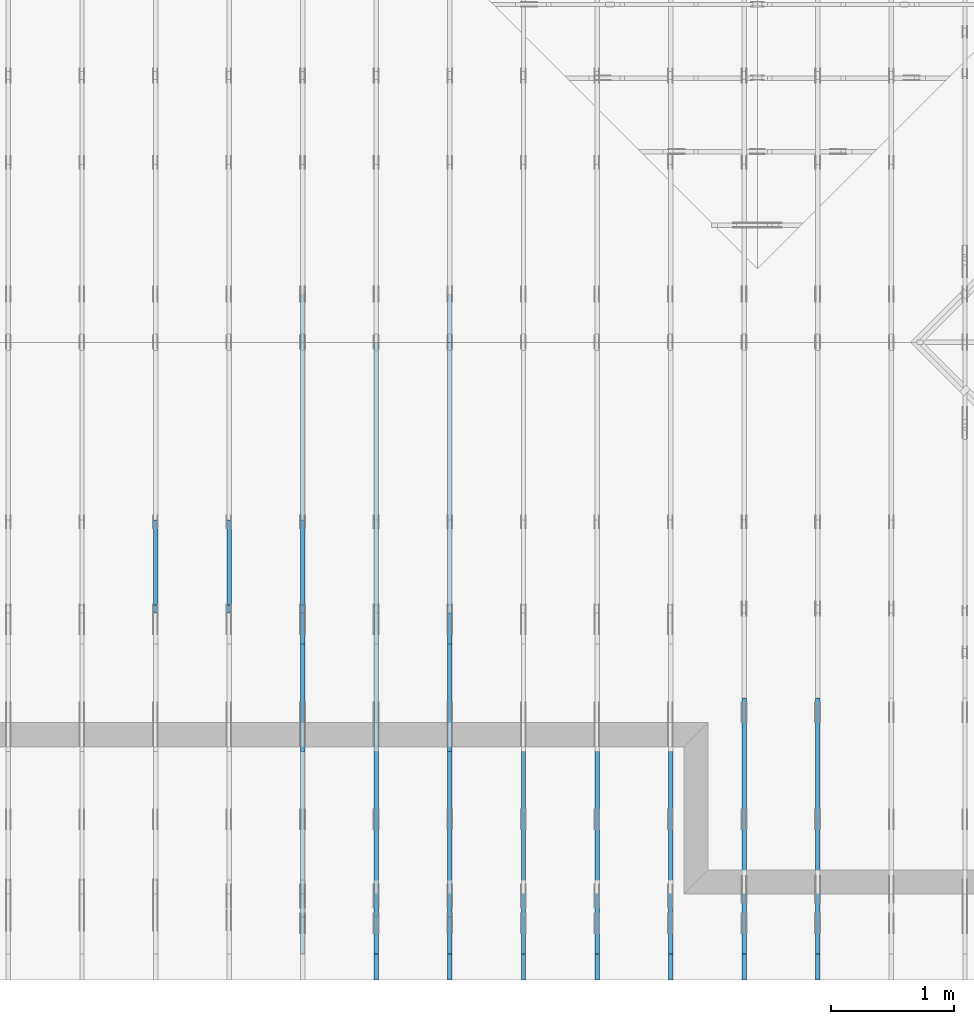
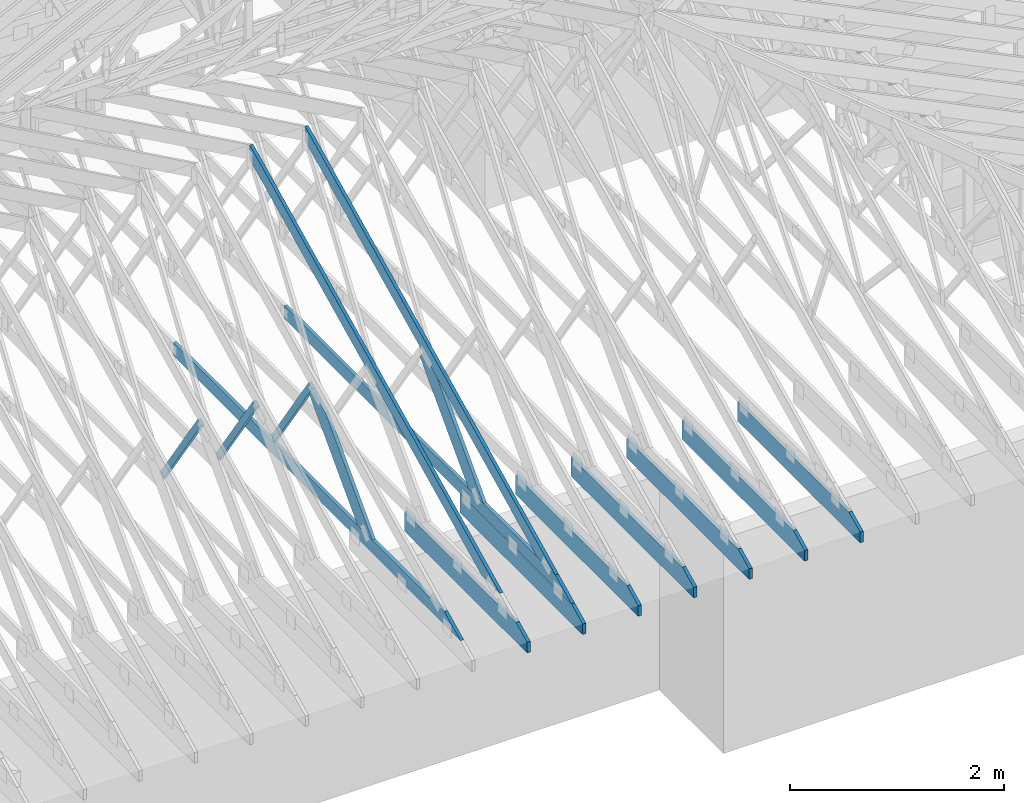
# One storey, part 13 of 159: 16 members, 10 elements without a shape of their own.
"""IFC2X3 building model written with IfcOpenShell, lengths in millimetres."""

from ifc_helpers import new_model, si_unit, frame, origin, origin_with_axes, origin_2d, place, context, project, spatial, faceted_brep, element, aggregate, save


model = new_model("IFC2X3")

# Units and contexts
model_context = context("Model", 3, precision=1e-05, world=origin())
plan_context = context("Plan", 2, precision=1e-05, world=origin_2d())
ifc_project = project(units=[si_unit("LENGTHUNIT", "METRE", prefix="MILLI"), si_unit("AREAUNIT", "SQUARE_METRE"), si_unit("VOLUMEUNIT", "CUBIC_METRE"), si_unit("SOLIDANGLEUNIT", "STERADIAN"), si_unit("PLANEANGLEUNIT", "RADIAN"), si_unit("MASSUNIT", "GRAM"), si_unit("TIMEUNIT", "SECOND"), si_unit("THERMODYNAMICTEMPERATUREUNIT", "DEGREE_CELSIUS"), si_unit("LUMINOUSINTENSITYUNIT", "LUMEN")], contexts=[model_context, plan_context])

# Site, building, storey
site_placement = place(None, origin_with_axes())
site = spatial("IfcSite", under=ifc_project, at=site_placement, CompositionType="ELEMENT")
building_placement = place(site_placement, origin_with_axes())
building = spatial("IfcBuilding", under=site, at=building_placement, Name="Plan 1", CompositionType="ELEMENT")
storey_placement = place(building_placement, origin_with_axes())
storey = spatial("IfcBuildingStorey", under=building, at=storey_placement, Name="Etasje 1", CompositionType="ELEMENT", Elevation=0.0)

# Assembly, member
assembly_1_placement = place(storey_placement, frame((15075.02226140475, -699.9989301294845, 1.1021457184401395e-15), z_axis=(-1.0, 1.836909530733566e-16, 6.123031769111886e-17), x_axis=(-1.836909530733566e-16, -1.0, 0.0)))
assembly_1 = element("IfcElementAssembly", 1, at=assembly_1_placement, inside=storey, Name="T7 (103)", AssemblyPlace="FACTORY", PredefinedType="TRUSS")
member_1_placement = place(assembly_1_placement, frame((-2299.9990234375, 0.0, -36.0), z_axis=(0.0, 0.0, 1.0), x_axis=(1.0, 0.0, 0.0)))
member_1 = element("IfcMember", 2, at=member_1_placement, Name="T7-U14", context=model_context, shape_type="Brep", body=[
    faceted_brep([(2088.8177337646484, 223.0, 36.0), (0.0, 223.0, 36.0), (0.0, 0.0, 36.0), (2300.0000933080446, 0.0, 36.0), (2300.0000933080446, 119.99948120117188, 36.0), (0.0, 223.0, 0.0), (2088.8177337646484, 223.0, 2.5579794687450473e-13), (2300.0000933080446, 119.99948120117188, 2.816594728057092e-13), (2300.0000933080446, 0.0, 2.816594728057092e-13), (0.0, 0.0, 0.0), (2088.8177277548316, 223.00000000000023, 2.524354896707238e-29), (2088.8177277548316, 223.00000000000023, 36.0), (2300.0000933080146, 119.99947818928456, 36.0), (2300.0000933080146, 119.99947818928456, 2.524354896707238e-29), (9.330801458418136e-05, 223.0, 0.0), (9.330801458418136e-05, 223.0, 36.0), (2088.817727754831, 222.99999999999986, 36.0), (2088.817727754831, 222.99999999999986, -7.888609052210118e-30), (9.330801458418136e-05, 0.0, 0.0), (9.330801458638566e-05, -2.6993892992798474e-31, 36.0), (9.330801461369438e-05, 223.0, 36.0), (9.330801461149009e-05, 223.0, -1.6721217180559947e-30), (2300.0000933080146, -4.2248920920855827e-13, 2.5869148500909603e-29), (2300.0000933080146, -4.20284917771678e-13, 36.0), (9.330801458418136e-05, 2.204274297042151e-15, 36.0), (9.330801458418136e-05, -1.713983812835093e-20, 1.0494777337732796e-36), (2300.0000933080146, 119.99947818928416, 0.0), (2300.0000933080146, 119.99947818928416, 36.0), (2300.0000933080146, 0.0, 36.0), (2300.0000933080146, 0.0, 0.0)], [[[0, 1, 2, 3, 4]], [[5, 6, 7, 8, 9]], [[10, 11, 12, 13]], [[14, 15, 16, 17]], [[18, 19, 20, 21]], [[22, 23, 24, 25]], [[26, 27, 28, 29]]]),
])
aggregate(assembly_1, [member_1])

assembly_2_placement = place(storey_placement, frame((14475.022261404752, -699.9989301294836, 1.1021457184401395e-15), z_axis=(-1.0, 1.836909530733566e-16, 6.123031769111886e-17), x_axis=(-1.836909530733566e-16, -1.0, 0.0)))
assembly_2 = element("IfcElementAssembly", 3, at=assembly_2_placement, inside=storey, Name="T10 (102)", AssemblyPlace="FACTORY", PredefinedType="TRUSS")
member_2_placement = place(assembly_2_placement, frame((-2299.9990234375, 0.0, -36.0), z_axis=(0.0, 0.0, 1.0), x_axis=(1.0, 0.0, 0.0)))
member_2 = element("IfcMember", 4, at=member_2_placement, Name="T10-U14", context=model_context, shape_type="Brep", body=[
    faceted_brep([(2088.8177337646484, 223.0, 36.0), (0.0, 223.0, 36.0), (0.0, 0.0, 36.0), (2300.0000933080446, 0.0, 36.0), (2300.0000933080446, 119.99948120117188, 36.0), (0.0, 223.0, 0.0), (2088.8177337646484, 223.0, 2.5579794687450473e-13), (2300.0000933080446, 119.99948120117188, 2.816594728057092e-13), (2300.0000933080446, 0.0, 2.816594728057092e-13), (0.0, 0.0, 0.0), (2088.8177277548316, 223.00000000000023, 2.524354896707238e-29), (2088.8177277548316, 223.00000000000023, 36.0), (2300.0000933080146, 119.99947818928456, 36.0), (2300.0000933080146, 119.99947818928456, 2.524354896707238e-29), (9.330801458418136e-05, 223.0, 0.0), (9.330801458418136e-05, 223.0, 36.0), (2088.817727754831, 222.99999999999986, 36.0), (2088.817727754831, 222.99999999999986, -7.888609052210118e-30), (9.330801458418136e-05, 0.0, 0.0), (9.330801458638566e-05, -2.6993892992798474e-31, 36.0), (9.330801461369438e-05, 223.0, 36.0), (9.330801461149009e-05, 223.0, -1.6721217180559947e-30), (2300.0000933080146, -4.2248920920855827e-13, 2.5869148500909603e-29), (2300.0000933080146, -4.20284917771678e-13, 36.0), (9.330801458418136e-05, 2.204274297042151e-15, 36.0), (9.330801458418136e-05, -1.713983812835093e-20, 1.0494777337732796e-36), (2300.0000933080146, 119.99947818928416, 0.0), (2300.0000933080146, 119.99947818928416, 36.0), (2300.0000933080146, 0.0, 36.0), (2300.0000933080146, 0.0, 0.0)], [[[0, 1, 2, 3, 4]], [[5, 6, 7, 8, 9]], [[10, 11, 12, 13]], [[14, 15, 16, 17]], [[18, 19, 20, 21]], [[22, 23, 24, 25]], [[26, 27, 28, 29]]]),
])
aggregate(assembly_2, [member_2])

assembly_3_placement = place(storey_placement, frame((13875.022261404752, -699.9989301294836, 1.1021457184401395e-15), z_axis=(-1.0, 1.836909530733566e-16, 6.123031769111886e-17), x_axis=(-1.836909530733566e-16, -1.0, 0.0)))
assembly_3 = element("IfcElementAssembly", 5, at=assembly_3_placement, inside=storey, Name="T6 (101)", AssemblyPlace="FACTORY", PredefinedType="TRUSS")
member_3_placement = place(assembly_3_placement, frame((-2299.9990234375, 0.0, -36.0), z_axis=(0.0, 0.0, 1.0), x_axis=(1.0, 0.0, 0.0)))
member_3 = element("IfcMember", 6, at=member_3_placement, Name="T6-U14", context=model_context, shape_type="Brep", body=[
    faceted_brep([(2088.8177337646484, 223.0, 36.0), (0.0, 223.0, 36.0), (0.0, 0.0, 36.0), (2300.0000933080446, 0.0, 36.0), (2300.0000933080446, 119.99948120117188, 36.0), (0.0, 223.0, 0.0), (2088.8177337646484, 223.0, 2.5579794687450473e-13), (2300.0000933080446, 119.99948120117188, 2.816594728057092e-13), (2300.0000933080446, 0.0, 2.816594728057092e-13), (0.0, 0.0, 0.0), (2088.8177277548316, 223.00000000000023, 2.524354896707238e-29), (2088.8177277548316, 223.00000000000023, 36.0), (2300.0000933080146, 119.99947818928456, 36.0), (2300.0000933080146, 119.99947818928456, 2.524354896707238e-29), (9.330801458418136e-05, 223.0, 0.0), (9.330801458418136e-05, 223.0, 36.0), (2088.817727754831, 222.99999999999986, 36.0), (2088.817727754831, 222.99999999999986, -7.888609052210118e-30), (9.330801458418136e-05, 0.0, 0.0), (9.330801458638566e-05, -2.6993892992798474e-31, 36.0), (9.330801461369438e-05, 223.0, 36.0), (9.330801461149009e-05, 223.0, -1.6721217180559947e-30), (2300.0000933080146, -4.2248920920855827e-13, 2.5869148500909603e-29), (2300.0000933080146, -4.20284917771678e-13, 36.0), (9.330801458418136e-05, 2.204274297042151e-15, 36.0), (9.330801458418136e-05, -1.713983812835093e-20, 1.0494777337732796e-36), (2300.0000933080146, 119.99947818928416, 0.0), (2300.0000933080146, 119.99947818928416, 36.0), (2300.0000933080146, 0.0, 36.0), (2300.0000933080146, 0.0, 0.0)], [[[0, 1, 2, 3, 4]], [[5, 6, 7, 8, 9]], [[10, 11, 12, 13]], [[14, 15, 16, 17]], [[18, 19, 20, 21]], [[22, 23, 24, 25]], [[26, 27, 28, 29]]]),
])
aggregate(assembly_3, [member_3])

assembly_4_placement = place(storey_placement, frame((13275.022261404752, -699.9989301294836, 1.1021457184401395e-15), z_axis=(-1.0, 1.836909530733566e-16, 6.123031769111886e-17), x_axis=(-1.836909530733566e-16, -1.0, 0.0)))
assembly_4 = element("IfcElementAssembly", 7, at=assembly_4_placement, inside=storey, Name="T6 (100)", AssemblyPlace="FACTORY", PredefinedType="TRUSS")
member_4_placement = place(assembly_4_placement, frame((-2299.9990234375, 0.0, -36.0), z_axis=(0.0, 0.0, 1.0), x_axis=(1.0, 0.0, 0.0)))
member_4 = element("IfcMember", 8, at=member_4_placement, Name="T6-U14", context=model_context, shape_type="Brep", body=[
    faceted_brep([(2088.8177337646484, 223.0, 36.0), (0.0, 223.0, 36.0), (0.0, 0.0, 36.0), (2300.0000933080446, 0.0, 36.0), (2300.0000933080446, 119.99948120117188, 36.0), (0.0, 223.0, 0.0), (2088.8177337646484, 223.0, 2.5579794687450473e-13), (2300.0000933080446, 119.99948120117188, 2.816594728057092e-13), (2300.0000933080446, 0.0, 2.816594728057092e-13), (0.0, 0.0, 0.0), (2088.8177277548316, 223.00000000000023, 2.524354896707238e-29), (2088.8177277548316, 223.00000000000023, 36.0), (2300.0000933080146, 119.99947818928456, 36.0), (2300.0000933080146, 119.99947818928456, 2.524354896707238e-29), (9.330801458418136e-05, 223.0, 0.0), (9.330801458418136e-05, 223.0, 36.0), (2088.817727754831, 222.99999999999986, 36.0), (2088.817727754831, 222.99999999999986, -7.888609052210118e-30), (9.330801458418136e-05, 0.0, 0.0), (9.330801458638566e-05, -2.6993892992798474e-31, 36.0), (9.330801461369438e-05, 223.0, 36.0), (9.330801461149009e-05, 223.0, -1.6721217180559947e-30), (2300.0000933080146, -4.2248920920855827e-13, 2.5869148500909603e-29), (2300.0000933080146, -4.20284917771678e-13, 36.0), (9.330801458418136e-05, 2.204274297042151e-15, 36.0), (9.330801458418136e-05, -1.713983812835093e-20, 1.0494777337732796e-36), (2300.0000933080146, 119.99947818928416, 0.0), (2300.0000933080146, 119.99947818928416, 36.0), (2300.0000933080146, 0.0, 36.0), (2300.0000933080146, 0.0, 0.0)], [[[0, 1, 2, 3, 4]], [[5, 6, 7, 8, 9]], [[10, 11, 12, 13]], [[14, 15, 16, 17]], [[18, 19, 20, 21]], [[22, 23, 24, 25]], [[26, 27, 28, 29]]]),
])
aggregate(assembly_4, [member_4])

assembly_5_placement = place(storey_placement, frame((12675.022261404752, -699.9989301294854, 4.558494966049043e-13), z_axis=(-1.0, 1.836909530733566e-16, 6.123031769111886e-17), x_axis=(-1.836909530733566e-16, -1.0, 0.0)))
assembly_5 = element("IfcElementAssembly", 9, at=assembly_5_placement, inside=storey, Name="T6 (99)", AssemblyPlace="FACTORY", PredefinedType="TRUSS")
member_5_placement = place(assembly_5_placement, frame((-2299.9990234375, 0.0, -36.0), z_axis=(0.0, 0.0, 1.0), x_axis=(1.0, 0.0, 0.0)))
member_5 = element("IfcMember", 10, at=member_5_placement, Name="T6-U14", context=model_context, shape_type="Brep", body=[
    faceted_brep([(2088.8177337646484, 223.0, 36.0), (0.0, 223.0, 36.0), (0.0, 0.0, 36.0), (2300.0000933080446, 0.0, 36.0), (2300.0000933080446, 119.99948120117188, 36.0), (0.0, 223.0, 0.0), (2088.8177337646484, 223.0, 2.5579794687450473e-13), (2300.0000933080446, 119.99948120117188, 2.816594728057092e-13), (2300.0000933080446, 0.0, 2.816594728057092e-13), (0.0, 0.0, 0.0), (2088.8177277548316, 223.00000000000023, 2.524354896707238e-29), (2088.8177277548316, 223.00000000000023, 36.0), (2300.0000933080146, 119.99947818928456, 36.0), (2300.0000933080146, 119.99947818928456, 2.524354896707238e-29), (9.330801458418136e-05, 223.0, 0.0), (9.330801458418136e-05, 223.0, 36.0), (2088.817727754831, 222.99999999999986, 36.0), (2088.817727754831, 222.99999999999986, -7.888609052210118e-30), (9.330801458418136e-05, 0.0, 0.0), (9.330801458638566e-05, -2.6993892992798474e-31, 36.0), (9.330801461369438e-05, 223.0, 36.0), (9.330801461149009e-05, 223.0, -1.6721217180559947e-30), (2300.0000933080146, -4.2248920920855827e-13, 2.5869148500909603e-29), (2300.0000933080146, -4.20284917771678e-13, 36.0), (9.330801458418136e-05, 2.204274297042151e-15, 36.0), (9.330801458418136e-05, -1.713983812835093e-20, 1.0494777337732796e-36), (2300.0000933080146, 119.99947818928416, 0.0), (2300.0000933080146, 119.99947818928416, 36.0), (2300.0000933080146, 0.0, 36.0), (2300.0000933080146, 0.0, 0.0)], [[[0, 1, 2, 3, 4]], [[5, 6, 7, 8, 9]], [[10, 11, 12, 13]], [[14, 15, 16, 17]], [[18, 19, 20, 21]], [[22, 23, 24, 25]], [[26, 27, 28, 29]]]),
])
aggregate(assembly_5, [member_5])

# Assembly, members
assembly_6_placement = place(storey_placement, frame((12075.022261404752, -699.9989301294854, 4.558494966049043e-13), z_axis=(-1.0, 1.836909530733566e-16, 6.123031769111886e-17), x_axis=(-1.836909530733566e-16, -1.0, 0.0)))
assembly_6 = element("IfcElementAssembly", 11, at=assembly_6_placement, inside=storey, Name="T5 (98)", AssemblyPlace="FACTORY", PredefinedType="TRUSS")
member_6_placement = place(assembly_6_placement, frame((-5264.878447895178, 2523.1876964355156, -36.0), z_axis=(0.0, 0.0, 1.0), x_axis=(0.8987940462991668, -0.4383711467890778, 0.0)))
member_6 = element("IfcMember", 12, at=member_6_placement, Name="T5-O3", context=model_context, shape_type="Brep", body=[
    faceted_brep([(5212.95535395332, 148.00000154094027, 36.0), (0.0, 148.00000154094027, 36.0), (72.18440200989608, 5.7974317996922764e-05, 36.0), (4909.510382240189, 5.7974317996922764e-05, 36.0), (0.0, 148.00000154094027, 0.0), (5212.95535395332, 148.00000154094027, 6.383818248643616e-13), (4909.510382240189, 5.7974317996922764e-05, 6.012217608248263e-13), (72.18440200989608, 5.7974317996922764e-05, 8.839747734818752e-15), (72.18447769922204, 9.2140264804641e-06, -7.888609052210118e-31), (72.18447769922206, 9.2140264804641e-06, 36.0), (5.4591825588090614e-05, 148.00000921330525, 36.0), (5.4591825588090614e-05, 148.00000921330525, -7.888609052210118e-31), (4909.510401129447, 9.21290418597988e-06, 1.6550270895783706e-28), (4909.510401129447, 9.212904188184172e-06, 36.0), (72.18447769922204, 9.21402643937418e-06, 36.0), (72.18447769922204, 9.214026437169889e-06, 2.433384460947949e-30), (5212.955369681814, 148.00000921223887, 1.0605704288840677e-29), (5212.955369681814, 148.00000921223887, 36.0), (4909.510401129447, 9.212906661559828e-06, 36.0), (4909.510401129447, 9.212906661559828e-06, -1.359749288005947e-29), (5.459182557387976e-05, 148.00000921330525, 0.0), (5.459182557387976e-05, 148.00000921330525, 36.0), (5212.955369681813, 148.00000921223887, 36.0), (5212.955369681813, 148.00000921223887, 7.888609052210118e-30)], [[[0, 1, 2, 3]], [[4, 5, 6, 7]], [[8, 9, 10, 11]], [[12, 13, 14, 15]], [[16, 17, 18, 19]], [[20, 21, 22, 23]]]),
])
member_7_placement = place(assembly_6_placement, frame((-211.18128967285153, 370.99999999999994, -36.0), z_axis=(0.0, 0.0, 1.0), x_axis=(-1.0, 1.2246063538223773e-16, 0.0)))
member_7 = element("IfcMember", 13, at=member_7_placement, Name="T5-U32", context=model_context, shape_type="Brep", body=[
    faceted_brep([(5379.999862670898, 148.00000000000063, 36.0), (0.0, 148.00000000000063, 36.0), (303.4449920654297, 0.0, 36.0), (5379.999862670898, 0.0, 36.0), (0.0, 148.00000000000063, 0.0), (5379.999862670898, 148.00000000000063, 6.588382015390299e-13), (5379.999862670898, 0.0, 6.588382015390299e-13), (303.4449920654297, 0.0, 3.7160066531890605e-14), (303.44497456401575, -1.8474111129762605e-13, 1.4199496293978212e-29), (303.44497456401575, -1.8474111129762605e-13, 36.0), (6.010755903673726e-06, 148.0, 36.0), (6.010755903673726e-06, 148.0, -1.5777218104420236e-30), (5380.000006010756, -1.0494167752128893e-12, 1.2690585325561372e-28), (5380.000006010756, -1.047212483776009e-12, 36.0), (303.44497456401587, -1.146952517202135e-13, 36.0), (303.44497456401587, -1.1689954315709379e-13, 7.157796165455513e-30), (5380.000006010756, 148.000000000001, 0.0), (5380.000006010756, 148.000000000001, 36.0), (5380.000006010756, 1.0231815394945443e-12, 36.0), (5380.000006010756, 1.0231815394945443e-12, 0.0), (6.010755896568298e-06, 147.99999999999997, 0.0), (6.010755896568298e-06, 147.99999999999997, 36.0), (5380.000006010756, 148.00000000000082, 36.0), (5380.000006010756, 148.00000000000082, -9.466330862652142e-30)], [[[0, 1, 2, 3]], [[4, 5, 6, 7]], [[8, 9, 10, 11]], [[12, 13, 14, 15]], [[16, 17, 18, 19]], [[20, 21, 22, 23]]]),
])
member_8_placement = place(assembly_6_placement, frame((-2299.9990234375, 0.0, -36.0), z_axis=(0.0, 0.0, 1.0), x_axis=(1.0, 0.0, 0.0)))
member_8 = element("IfcMember", 14, at=member_8_placement, Name="T5-U14", context=model_context, shape_type="Brep", body=[
    faceted_brep([(2088.8177337646484, 223.0, 36.0), (0.0, 223.0, 36.0), (0.0, 0.0, 36.0), (2300.0000933080446, 0.0, 36.0), (2300.0000933080446, 119.99948120117188, 36.0), (0.0, 223.0, 0.0), (2088.8177337646484, 223.0, 2.5579794687450473e-13), (2300.0000933080446, 119.99948120117188, 2.816594728057092e-13), (2300.0000933080446, 0.0, 2.816594728057092e-13), (0.0, 0.0, 0.0), (2088.8177277548316, 223.00000000000023, 2.524354896707238e-29), (2088.8177277548316, 223.00000000000023, 36.0), (2300.0000933080146, 119.99947818928456, 36.0), (2300.0000933080146, 119.99947818928456, 2.524354896707238e-29), (9.330801458418136e-05, 223.0, 0.0), (9.330801458418136e-05, 223.0, 36.0), (2088.817727754831, 222.99999999999986, 36.0), (2088.817727754831, 222.99999999999986, -7.888609052210118e-30), (9.330801458418136e-05, 0.0, 0.0), (9.330801458638566e-05, -2.6993892992798474e-31, 36.0), (9.330801461369438e-05, 223.0, 36.0), (9.330801461149009e-05, 223.0, -1.6721217180559947e-30), (2300.0000933080146, -4.2248920920855827e-13, 2.5869148500909603e-29), (2300.0000933080146, -4.20284917771678e-13, 36.0), (9.330801458418136e-05, 2.204274297042151e-15, 36.0), (9.330801458418136e-05, -1.713983812835093e-20, 1.0494777337732796e-36), (2300.0000933080146, 119.99947818928416, 0.0), (2300.0000933080146, 119.99947818928416, 36.0), (2300.0000933080146, 0.0, 36.0), (2300.0000933080146, 0.0, 0.0)], [[[0, 1, 2, 3, 4]], [[5, 6, 7, 8, 9]], [[10, 11, 12, 13]], [[14, 15, 16, 17]], [[18, 19, 20, 21]], [[22, 23, 24, 25]], [[26, 27, 28, 29]]]),
])
member_9_placement = place(assembly_6_placement, frame((-3064.6757649958863, 1346.8492734428223, -36.0), z_axis=(0.0, 0.0, 1.0), x_axis=(0.6894016878176602, -0.7243792603561765, 0.0)))
member_9 = element("IfcMember", 15, at=member_9_placement, Name="T5-D3", context=model_context, shape_type="Brep", body=[
    faceted_brep([(1535.5918255141082, 198.00009159272804, 36.0), (265.95807658513104, 198.00009159272804, 36.0), (0.0, 99.00008285369722, 36.0), (21.1644449327855, 0.0, 36.0), (1347.1524748391525, 0.0, 36.0), (265.95807658513104, 198.00009159272804, 3.256939504365299e-14), (1535.5918255141082, 198.00009159272804, 1.8804955064022803e-13), (1347.1524748391525, 0.0, 1.6497314802555664e-13), (21.1644449327855, 0.0, 2.5918113739812938e-15), (0.0, 99.00008285369722, 0.0), (4.264463813541397e-05, 99.00009494304574, 8.9528506660674e-31), (4.264463813541397e-05, 99.00009494304574, 36.0), (265.9581340926615, 198.000094942845, 36.0), (265.9581340926615, 198.000094942845, 5.714073875343044e-30), (21.164497648067943, 9.494284540778608e-05, -1.97215226305253e-31), (21.164497648067943, 9.494284540867426e-05, 36.0), (4.264463818515196e-05, 99.00009494304575, 36.0), (4.264463818159925e-05, 99.00009494304575, -2.5637979419682884e-30), (1347.1525101598781, 9.494284280359457e-05, 2.0233849336071296e-29), (1347.1525101598781, 9.494284280579886e-05, 36.0), (21.164497648067936, 9.494284540479874e-05, 36.0), (21.164497648067936, 9.494284540259445e-05, 3.1788526975049665e-31), (1535.5918287024588, 198.00009494284234, 5.048709793414476e-29), (1535.5918287024588, 198.00009494284234, 36.0), (1347.1525101598784, 9.494284279298881e-05, 36.0), (1347.1525101598784, 9.494284279298881e-05, 3.7865323450608567e-29), (265.95813409266157, 198.00009494284495, 0.0), (265.95813409266157, 198.00009494284495, 36.0), (1535.5918287024583, 198.00009494284262, 36.0), (1535.5918287024583, 198.00009494284262, -4.733165431326071e-30)], [[[0, 1, 2, 3, 4]], [[5, 6, 7, 8, 9]], [[10, 11, 12, 13]], [[14, 15, 16, 17]], [[18, 19, 20, 21]], [[22, 23, 24, 25]], [[26, 27, 28, 29]]]),
])
aggregate(assembly_6, [member_6, member_7, member_8, member_9])

assembly_7_placement = place(storey_placement, frame((11475.022261404752, -699.9989301294845, 1.1021457184401395e-15), z_axis=(-1.0, 1.836909530733566e-16, 6.123031769111886e-17), x_axis=(-1.836909530733566e-16, -1.0, 0.0)))
assembly_7 = element("IfcElementAssembly", 16, at=assembly_7_placement, inside=storey, Name="T5 (97)", AssemblyPlace="FACTORY", PredefinedType="TRUSS")
member_10_placement = place(assembly_7_placement, frame((-5264.878447895178, 2523.1876964355156, -36.0), z_axis=(0.0, 0.0, 1.0), x_axis=(0.8987940462991668, -0.4383711467890778, 0.0)))
member_10 = element("IfcMember", 17, at=member_10_placement, Name="T5-O3", context=model_context, shape_type="Brep", body=[
    faceted_brep([(5212.95535395332, 148.00000154094027, 36.0), (0.0, 148.00000154094027, 36.0), (72.18440200989608, 5.7974317996922764e-05, 36.0), (4909.510382240189, 5.7974317996922764e-05, 36.0), (0.0, 148.00000154094027, 0.0), (5212.95535395332, 148.00000154094027, 6.383818248643616e-13), (4909.510382240189, 5.7974317996922764e-05, 6.012217608248263e-13), (72.18440200989608, 5.7974317996922764e-05, 8.839747734818752e-15), (72.18447769922204, 9.2140264804641e-06, -7.888609052210118e-31), (72.18447769922206, 9.2140264804641e-06, 36.0), (5.4591825588090614e-05, 148.00000921330525, 36.0), (5.4591825588090614e-05, 148.00000921330525, -7.888609052210118e-31), (4909.510401129447, 9.21290418597988e-06, 1.6550270895783706e-28), (4909.510401129447, 9.212904188184172e-06, 36.0), (72.18447769922204, 9.21402643937418e-06, 36.0), (72.18447769922204, 9.214026437169889e-06, 2.433384460947949e-30), (5212.955369681814, 148.00000921223887, 1.0605704288840677e-29), (5212.955369681814, 148.00000921223887, 36.0), (4909.510401129447, 9.212906661559828e-06, 36.0), (4909.510401129447, 9.212906661559828e-06, -1.359749288005947e-29), (5.459182557387976e-05, 148.00000921330525, 0.0), (5.459182557387976e-05, 148.00000921330525, 36.0), (5212.955369681813, 148.00000921223887, 36.0), (5212.955369681813, 148.00000921223887, 7.888609052210118e-30)], [[[0, 1, 2, 3]], [[4, 5, 6, 7]], [[8, 9, 10, 11]], [[12, 13, 14, 15]], [[16, 17, 18, 19]], [[20, 21, 22, 23]]]),
])
member_11_placement = place(assembly_7_placement, frame((-2299.9990234375, 0.0, -36.0), z_axis=(0.0, 0.0, 1.0), x_axis=(1.0, 0.0, 0.0)))
member_11 = element("IfcMember", 18, at=member_11_placement, Name="T5-U14", context=model_context, shape_type="Brep", body=[
    faceted_brep([(2088.8177337646484, 223.0, 36.0), (0.0, 223.0, 36.0), (0.0, 0.0, 36.0), (2300.0000933080446, 0.0, 36.0), (2300.0000933080446, 119.99948120117188, 36.0), (0.0, 223.0, 0.0), (2088.8177337646484, 223.0, 2.5579794687450473e-13), (2300.0000933080446, 119.99948120117188, 2.816594728057092e-13), (2300.0000933080446, 0.0, 2.816594728057092e-13), (0.0, 0.0, 0.0), (2088.8177277548316, 223.00000000000023, 2.524354896707238e-29), (2088.8177277548316, 223.00000000000023, 36.0), (2300.0000933080146, 119.99947818928456, 36.0), (2300.0000933080146, 119.99947818928456, 2.524354896707238e-29), (9.330801458418136e-05, 223.0, 0.0), (9.330801458418136e-05, 223.0, 36.0), (2088.817727754831, 222.99999999999986, 36.0), (2088.817727754831, 222.99999999999986, -7.888609052210118e-30), (9.330801458418136e-05, 0.0, 0.0), (9.330801458638566e-05, -2.6993892992798474e-31, 36.0), (9.330801461369438e-05, 223.0, 36.0), (9.330801461149009e-05, 223.0, -1.6721217180559947e-30), (2300.0000933080146, -4.2248920920855827e-13, 2.5869148500909603e-29), (2300.0000933080146, -4.20284917771678e-13, 36.0), (9.330801458418136e-05, 2.204274297042151e-15, 36.0), (9.330801458418136e-05, -1.713983812835093e-20, 1.0494777337732796e-36), (2300.0000933080146, 119.99947818928416, 0.0), (2300.0000933080146, 119.99947818928416, 36.0), (2300.0000933080146, 0.0, 36.0), (2300.0000933080146, 0.0, 0.0)], [[[0, 1, 2, 3, 4]], [[5, 6, 7, 8, 9]], [[10, 11, 12, 13]], [[14, 15, 16, 17]], [[18, 19, 20, 21]], [[22, 23, 24, 25]], [[26, 27, 28, 29]]]),
])
aggregate(assembly_7, [member_10, member_11])

assembly_8_placement = place(storey_placement, frame((10875.02226140475, -699.9989301294845, 1.1021457184401395e-15), z_axis=(-1.0, 1.836909530733566e-16, 6.123031769111886e-17), x_axis=(-1.836909530733566e-16, -1.0, 0.0)))
assembly_8 = element("IfcElementAssembly", 19, at=assembly_8_placement, inside=storey, Name="T4 (96)", AssemblyPlace="FACTORY", PredefinedType="TRUSS")
member_12_placement = place(assembly_8_placement, frame((-211.18128967285153, 370.99999999999994, -36.0), z_axis=(0.0, 0.0, 1.0), x_axis=(-1.0, 1.2246063538223773e-16, 0.0)))
member_12 = element("IfcMember", 20, at=member_12_placement, Name="T4-U32", context=model_context, shape_type="Brep", body=[
    faceted_brep([(5379.999862670898, 148.00000000000063, 36.0), (0.0, 148.00000000000063, 36.0), (303.4449920654297, 0.0, 36.0), (5379.999862670898, 0.0, 36.0), (0.0, 148.00000000000063, 0.0), (5379.999862670898, 148.00000000000063, 6.588382015390299e-13), (5379.999862670898, 0.0, 6.588382015390299e-13), (303.4449920654297, 0.0, 3.7160066531890605e-14), (303.44497456401575, -1.8474111129762605e-13, 1.4199496293978212e-29), (303.44497456401575, -1.8474111129762605e-13, 36.0), (6.010755903673726e-06, 148.0, 36.0), (6.010755903673726e-06, 148.0, -1.5777218104420236e-30), (5380.000006010756, -1.0494167752128893e-12, 1.2690585325561372e-28), (5380.000006010756, -1.047212483776009e-12, 36.0), (303.44497456401587, -1.146952517202135e-13, 36.0), (303.44497456401587, -1.1689954315709379e-13, 7.157796165455513e-30), (5380.000006010756, 148.000000000001, 0.0), (5380.000006010756, 148.000000000001, 36.0), (5380.000006010756, 1.0231815394945443e-12, 36.0), (5380.000006010756, 1.0231815394945443e-12, 0.0), (6.010755896568298e-06, 147.99999999999997, 0.0), (6.010755896568298e-06, 147.99999999999997, 36.0), (5380.000006010756, 148.00000000000082, 36.0), (5380.000006010756, 148.00000000000082, -9.466330862652142e-30)], [[[0, 1, 2, 3]], [[4, 5, 6, 7]], [[8, 9, 10, 11]], [[12, 13, 14, 15]], [[16, 17, 18, 19]], [[20, 21, 22, 23]]]),
])
member_13_placement = place(assembly_8_placement, frame((-3053.2314180439453, 1456.2901995043017, -36.00000000000001), z_axis=(0.0, 0.0, 1.0), x_axis=(-0.5642475050080044, -0.8256056886263821, 0.0)))
member_13 = element("IfcMember", 21, at=member_13_placement, Name="T4-D42", context=model_context, shape_type="Brep", body=[
    faceted_brep([(1264.6473178393353, 73.00019836058664, 36.0), (2.90698949356738e-06, 73.00019836058664, 36.0), (10.714657584819633, 4.511090492087533e-05, 36.0), (1236.186095030735, 4.511090492087533e-05, 36.0), (2.90698949356738e-06, 73.00019836058664, 3.5599178043175084e-22), (1264.6473178393353, 73.00019836058664, 1.5486951407704775e-13), (1236.186095030735, 4.511090492087533e-05, 1.5138413464815112e-13), (10.714657584819633, 4.511090492087533e-05, 1.3121237757401251e-15), (10.714685884898016, 0.00010020237868935133, 1.010048471493429e-31), (10.714685884898017, 0.00010020237868957338, 36.0), (3.375077994860476e-14, 73.00010020237825, 36.0), (3.197442310920451e-14, 73.00010020237825, -2.1820420316813824e-30), (1236.1860298820347, 0.00010020237954454694, 5.902699555591949e-29), (1236.1860298820347, 0.00010020237954675123, 36.0), (10.714685884898017, 0.00010020237868342204, 36.0), (10.714685884898017, 0.00010020237868121774, 5.116180235117775e-31), (1264.6473849240515, 73.00010020238051, 2.686871379716991e-29), (1264.6473849240515, 73.00010020238051, 36.0), (1236.1860298820352, 0.00010020238050856278, 36.0), (1236.1860298820352, 0.00010020238050856278, 2.662727280413415e-29), (0.0, 73.00010020237823, 0.0), (0.0, 73.00010020237823, 36.0), (1264.647384924051, 73.0001002023804, 36.0), (1264.647384924051, 73.00010020238041, -7.099748146989106e-30)], [[[0, 1, 2, 3]], [[4, 5, 6, 7]], [[8, 9, 10, 11]], [[12, 13, 14, 15]], [[16, 17, 18, 19]], [[20, 21, 22, 23]]]),
])
member_14_placement = place(assembly_8_placement, frame((-3064.6757649958863, 1346.8492734428223, -36.0), z_axis=(0.0, 0.0, 1.0), x_axis=(0.6894016878176602, -0.7243792603561765, 0.0)))
member_14 = element("IfcMember", 22, at=member_14_placement, Name="T4-D3", context=model_context, shape_type="Brep", body=[
    faceted_brep([(1535.5918255141082, 198.00009159272804, 36.0), (265.95807658513104, 198.00009159272804, 36.0), (0.0, 99.00008285369722, 36.0), (21.1644449327855, 0.0, 36.0), (1347.1524748391525, 0.0, 36.0), (265.95807658513104, 198.00009159272804, 3.256939504365299e-14), (1535.5918255141082, 198.00009159272804, 1.8804955064022803e-13), (1347.1524748391525, 0.0, 1.6497314802555664e-13), (21.1644449327855, 0.0, 2.5918113739812938e-15), (0.0, 99.00008285369722, 0.0), (4.264463813541397e-05, 99.00009494304574, 8.9528506660674e-31), (4.264463813541397e-05, 99.00009494304574, 36.0), (265.9581340926615, 198.000094942845, 36.0), (265.9581340926615, 198.000094942845, 5.714073875343044e-30), (21.164497648067943, 9.494284540778608e-05, -1.97215226305253e-31), (21.164497648067943, 9.494284540867426e-05, 36.0), (4.264463818515196e-05, 99.00009494304575, 36.0), (4.264463818159925e-05, 99.00009494304575, -2.5637979419682884e-30), (1347.1525101598781, 9.494284280359457e-05, 2.0233849336071296e-29), (1347.1525101598781, 9.494284280579886e-05, 36.0), (21.164497648067936, 9.494284540479874e-05, 36.0), (21.164497648067936, 9.494284540259445e-05, 3.1788526975049665e-31), (1535.5918287024588, 198.00009494284234, 5.048709793414476e-29), (1535.5918287024588, 198.00009494284234, 36.0), (1347.1525101598784, 9.494284279298881e-05, 36.0), (1347.1525101598784, 9.494284279298881e-05, 3.7865323450608567e-29), (265.95813409266157, 198.00009494284495, 0.0), (265.95813409266157, 198.00009494284495, 36.0), (1535.5918287024583, 198.00009494284262, 36.0), (1535.5918287024583, 198.00009494284262, -4.733165431326071e-30)], [[[0, 1, 2, 3, 4]], [[5, 6, 7, 8, 9]], [[10, 11, 12, 13]], [[14, 15, 16, 17]], [[18, 19, 20, 21]], [[22, 23, 24, 25]], [[26, 27, 28, 29]]]),
])
aggregate(assembly_8, [member_12, member_13, member_14])

# Assembly, member
assembly_9_placement = place(storey_placement, frame((10275.02226140475, -699.9989301294845, 1.1021457184401395e-15), z_axis=(-1.0, 1.836909530733566e-16, 6.123031769111886e-17), x_axis=(-1.836909530733566e-16, -1.0, 0.0)))
assembly_9 = element("IfcElementAssembly", 23, at=assembly_9_placement, inside=storey, Name="T3 (95)", AssemblyPlace="FACTORY", PredefinedType="TRUSS")
member_15_placement = place(assembly_9_placement, frame((-3053.2313819478163, 1456.2901728028276, -36.00000000000001), z_axis=(0.0, 0.0, 1.0), x_axis=(-0.5642474862457515, -0.8256057014491548, 0.0)))
member_15 = element("IfcMember", 24, at=member_15_placement, Name="T3-D42", context=model_context, shape_type="Brep", body=[
    faceted_brep([(1264.6473178205576, 73.00012475351014, 36.0), (2.8882086553494446e-06, 73.00012475351014, 36.0), (10.714655907081578, 0.0, 36.0), (1236.1859555972615, 0.0, 36.0), (2.8882086553494446e-06, 73.00012475351014, 3.5369186705057144e-22), (1264.6473178205576, 73.00012475351014, 1.5486951407474822e-13), (1236.1859555972615, 0.0, 1.5138411757303936e-13), (10.714655907081578, 0.0, 1.3121235702832567e-15), (10.714684190227448, 5.5212697134487954e-05, -1.9721522630525295e-31), (10.71468419022745, 5.521269713471e-05, 36.0), (1.7763568394002505e-14, 73.0000552126976, 36.0), (1.5987211554602254e-14, 73.0000552126976, -1.1832913578315177e-30), (1236.1860093219798, 5.52126990752652e-05, 7.606227022046546e-29), (1236.1860093219798, 5.521269907746949e-05, 36.0), (10.714684190227445, 5.521269712570312e-05, 36.0), (10.714684190227445, 5.5212697123498826e-05, 6.5927215103720925e-31), (1264.647365347152, 73.00005521269998, -1.6251647205105496e-30), (1264.647365347152, 73.00005521269998, 36.0), (1236.1860093219798, 5.5212700374340784e-05, 36.0), (1236.1860093219798, 5.5212700374340784e-05, -1.383723726374294e-30), (0.0, 73.00005521269759, 0.0), (0.0, 73.00005521269759, 36.0), (1264.647365347152, 73.00005521269975, 36.0), (1264.647365347152, 73.00005521269976, -7.099748146989106e-30)], [[[0, 1, 2, 3]], [[4, 5, 6, 7]], [[8, 9, 10, 11]], [[12, 13, 14, 15]], [[16, 17, 18, 19]], [[20, 21, 22, 23]]]),
])
aggregate(assembly_9, [member_15])

assembly_10_placement = place(storey_placement, frame((9675.022261404752, 9699.99999999999, 1.1021457184401395e-15), z_axis=(-1.0, 1.836909530733566e-16, 6.123031769111886e-17), x_axis=(-1.836909530733566e-16, -1.0, 0.0)))
assembly_10 = element("IfcElementAssembly", 25, at=assembly_10_placement, inside=storey, Name="T2 (94)", AssemblyPlace="FACTORY", PredefinedType="TRUSS")
member_16_placement = place(assembly_10_placement, frame((7346.76744651809, 1456.2902443153225, -36.0), z_axis=(0.0, 0.0, 1.0), x_axis=(-0.564247505007227, -0.8256056886269131, 0.0)))
member_16 = element("IfcMember", 26, at=member_16_placement, Name="T2-D42", context=model_context, shape_type="Brep", body=[
    faceted_brep([(1264.6472651905533, 73.00035481239047, 36.0), (8.801394596957834e-05, 73.00035481239047, 36.0), (10.714742691707215, 0.0, 36.0), (1236.1859046261452, 0.0, 36.0), (8.801394596957834e-05, 73.00035481239047, 1.0778243745932505e-20), (1264.6472651905533, 73.00035481239047, 1.5486950762964446e-13), (1236.1859046261452, 0.0, 1.5138411133108407e-13), (10.714742691707215, 0.0, 1.3121341979836537e-15), (10.714685884831852, 0.0001796189581002583, -9.62105002194463e-32), (10.714685884831855, 0.00017961895810048034, 36.0), (-2.6645352591003757e-14, 73.0001796189581, 36.0), (-2.842170943040401e-14, 73.0001796189581, 1.7622623733601546e-30), (1236.1860298817128, 0.00017961895895500981, 5.902699630823587e-29), (1236.1860298817128, 0.0001796189589572141, 36.0), (10.714685884831852, 0.0001796189580938849, 36.0), (10.714685884831852, 0.0001796189580916806, 5.1161877582816205e-31), (1264.6473849238073, 73.00017961895986, 0.0), (1264.6473849238073, 73.00017961895986, 36.0), (1236.1860298817128, 0.00017961895991902566, 36.0), (1236.1860298817128, 0.00017961895991902566, 0.0), (0.0, 73.0001796189581, 0.0), (0.0, 73.0001796189581, 36.0), (1264.6473849238073, 73.00017961895999, 36.0), (1264.6473849238073, 73.00017961895999, 4.733165431326071e-30)], [[[0, 1, 2, 3]], [[4, 5, 6, 7]], [[8, 9, 10, 11]], [[12, 13, 14, 15]], [[16, 17, 18, 19]], [[20, 21, 22, 23]]]),
])
aggregate(assembly_10, [member_16])

save(model, "model.ifc")
